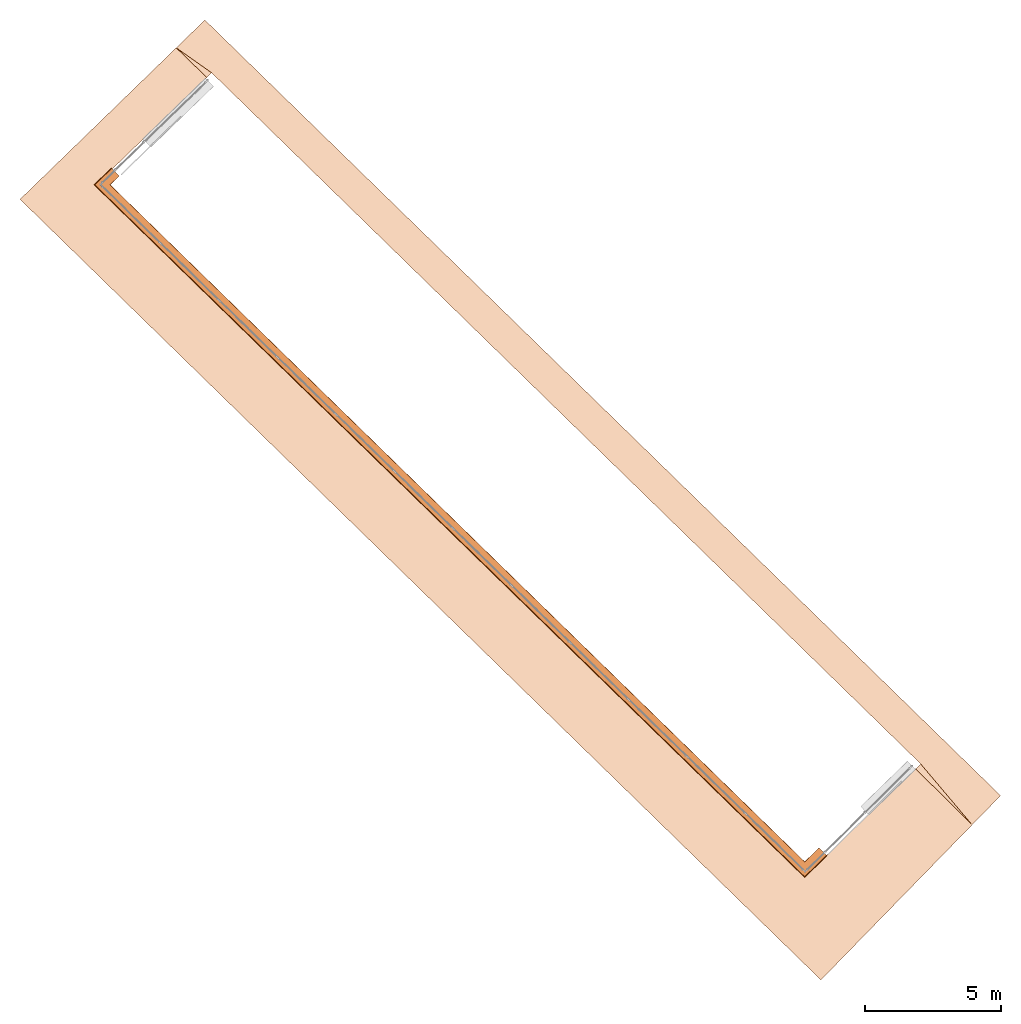
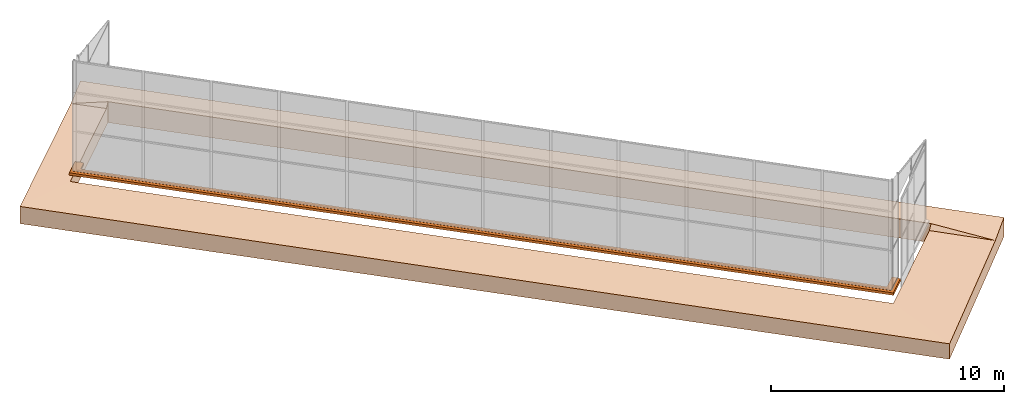
# One storey, part 13 of 13: 1 geographic element, 1 proxy.
"""IFC4 building model written with IfcOpenShell, lengths in metres."""

from ifc_helpers import new_model, entity, si_unit, converted_unit, direction, frame, origin, place, context, subcontext, project, spatial, polygons, source, transform, mapped, material, type_object, type_shapes, element, save


model = new_model("IFC4")

# Units and contexts
model_context = context("Model", 3, precision=1e-05, world=origin(), true_north=direction((6.123233995736766e-17, 1.0)))
body_context = subcontext(model_context, "Body", "Model", "MODEL_VIEW")
ifc_project = project(units=[si_unit("LENGTHUNIT", "METRE"), si_unit("AREAUNIT", "SQUARE_METRE"), si_unit("VOLUMEUNIT", "CUBIC_METRE"), converted_unit("PLANEANGLEUNIT", "DEGREE", entity("IfcPlaneAngleMeasure", 0.017453292519943278), si_unit("PLANEANGLEUNIT", "RADIAN"), dimensions=[0, 0, 0, 0, 0, 0, 0])], contexts=[model_context])

# Site, building, storey
site_placement = place(None, frame((0.0, 0.0, 0.0), z_axis=(0.0, 0.0, 1.0), x_axis=(0.7160934825303189, -0.6980043870045516, 0.0)))
site = spatial("IfcSite", under=ifc_project, at=site_placement, CompositionType="ELEMENT")
building_placement = place(site_placement, origin())
building = spatial("IfcBuilding", under=site, at=building_placement, CompositionType="ELEMENT")
storey_placement = place(building_placement, frame((0.0, 0.0, -7.0)))
storey = spatial("IfcBuildingStorey", under=building, at=storey_placement, Name="-7.00 m", CompositionType="ELEMENT", Elevation=-7.000000000000001)

# Geographic element
ifc_material_1 = material(Name="Terra", Category="Generico")
geographic_element_type = type_object("IfcGeographicElementType", Name="Solido Generico - 1000 mm", PredefinedType="TERRAIN", material=ifc_material_1)
geographic_element_placement = place(storey_placement, origin())
element("IfcGeographicElement", 1, at=geographic_element_placement, inside=storey, type_object=geographic_element_type, material=ifc_material_1, Name="Solido Generico - 1000 mm", ObjectType="Solido Generico - 1000 mm", PredefinedType="TERRAIN", context=body_context, shape_type="Tessellation", body=[
    polygons([(11.532684703476185, 0.02832929454570762, -1.3334398928547868), (11.532684703476187, -1.4706707054542927, -1.3334398928547868), (11.532684703476187, -9.430854376535772, -1.3334398928547868), (-29.559637767124112, -9.430854376535772, -1.3334398928547868), (-29.335912246860154, -1.4380963473800092, -1.3334398928547868), (-29.294865484469565, 0.02832929454570762, -1.3334398928547868), (8.610409894070742, -1.4433656579759988, -1.3334398928547868), (8.617572791938493, -1.1874658867878702, -1.3334398928547868), (-27.76667232391627, -1.1874658867878725, -1.3334398928547868), (-27.77355542108607, -1.433369573163963, -1.3334398928547868), (-27.93211017841002, -7.097854376535773, -1.3334398928547868), (8.452134937444777, -7.097854376535772, -1.3334398928547868), (11.532684703476184, 0.028329294545739528, -0.3354398928547857), (11.532684703476187, -1.4706707054542927, -0.5284398928547862), (11.532684703476187, -9.430854376535772, -0.5284398928547862), (-29.559637767124116, -9.43085437653577, -0.4324398928547861), (-29.33591224686015, -1.4380963473800092, -0.43243989285478523), (-29.294865484469558, 0.02832929454565502, -0.23943989285478473), (8.617572791938494, -1.187465886787851, -0.3354398928547857), (-27.766672323916268, -1.187465886787878, -0.23943989285478473), (-27.773555421086066, -1.433369573163964, -0.4324398928547861), (-27.932110178410024, -7.097854376535772, -0.4324398928547861), (8.452134937444779, -7.097854376535774, -0.5284398928547862), (8.610409894070742, -1.4433656579759986, -0.5284398928547862)], [[[1, 2, 3, 4, 5, 6], [7, 8, 9, 10, 11, 12]], [[2, 1, 13, 14]], [[4, 3, 15, 16]], [[5, 4, 16, 17]], [[1, 6, 18, 13]], [[9, 8, 19, 20]], [[10, 9, 20, 21]], [[12, 11, 22, 23]], [[7, 12, 23, 24]], [[3, 2, 14, 15]], [[6, 5, 17, 18]], [[8, 7, 24, 19]], [[11, 10, 21, 22]], [[16, 15, 23]], [[16, 23, 22]], [[16, 22, 21, 17]], [[20, 19, 18]], [[13, 19, 14]], [[13, 18, 19]], [[20, 18, 17]], [[20, 17, 21]], [[23, 15, 14, 24]], [[14, 19, 24]]], closed=True),
])

# Proxy
ifc_material_2 = material()
building_element_proxy_type = type_object("IfcBuildingElementProxyType", Name="Muro1:Muro", PredefinedType="NOTDEFINED", material=ifc_material_2)
shared_shape = source(origin(), body_context, "Body", "Tessellation", [
    polygons([(36.33182419133019, 1.1442330811412054, 0.13300000000005532), (36.33632242949564, 1.144107170827123, 0.12520577136594274), (36.47243725114863, 1.1402971769327928, 0.11100000000000292), (36.49487005115399, 1.139669259781557, 2.1657342585967855e-15), (36.443502514958, 1.141107089967108, 2.1657342585967855e-15), (36.443502514958, 1.141107089967108, 0.07300000000000614), (36.09363954653669, 1.1509001143956759, 0.07300000000000723), (36.09363954653669, 1.1509001143956759, 0.004000000000005588), (36.088641504130706, 1.1510400147446542, 0.004000000000005588), (36.08579560929231, 1.1511196742690655, 0.014625184089175895), (36.08579560929231, 1.1511196742690655, 0.05962518408918299), (36.078020480000816, 1.151337308137063, 0.06740335868223715), (36.08362427494708, 1.1511804521512783, 0.1130604816577353), (36.177395605690755, 1.148555696130898, 0.13300000000005532), (0.18787124100893632, 0.8823410992782678, 0.13300000000005532), (0.34229982664837544, 0.8780184842885752, 0.13300000000005532), (0.4360711573920589, 0.8753937282681948, 0.1130604816577353), (0.4416749523383237, 0.87523687228241, 0.06740335868223715), (0.4338998230468252, 0.8754545061504087, 0.05962518408918299), (0.4338998230468252, 0.8754545061504087, 0.014625184089175895), (0.43105392820842736, 0.8755341656748199, 0.004000000000005588), (0.42605588580243986, 0.8756740660237984, 0.004000000000005588), (0.42605588580243986, 0.8756740660237984, 0.07300000000004296), (0.07619291738113558, 0.885467090452365, 0.07300000000008086), (0.07619291738113125, 0.885467090452365, 2.1657342585967855e-15), (0.024825381185144182, 0.8869049206379152, 2.1657342585967855e-15), (0.04725818119050175, 0.8862770034866815, 0.11100000000000292), (0.1833730028434895, 0.88246700959235, 0.12520577136594274), (36.304361539072175, 0.16310972034517862, 0.13300000000005532), (36.3087373419672, 0.15860972034515042, 0.12520577136594166), (36.44114732310624, 0.022441586308217, 0.11100000000000292), (36.462969536069785, 1.0828671292983927e-15, 2.1657342585967855e-15), (4.331468517193571e-15, 1.0828671292983927e-15, 2.1657342585967855e-15), (0.05284617588572552, 0.05138765542899253, 2.1657342585967855e-15), (36.41300014687123, 0.051387655428993616, 2.1657342585967855e-15), (36.41300014687123, 0.051387655428993616, 0.07300000000000614), (0.05284617588572985, 0.05138765542899253, 0.07300000000008086), (0.4127801212193844, 0.40138765542902777, 0.07300000000000723), (36.07265992170444, 0.40138765542902666, 0.07300000000000723), (36.07265992170444, 0.40138765542902666, 0.004000000000005588), (0.41278012121937574, 0.40138765542902666, 0.004000000000005588), (0.41792203472411116, 0.40638765542899413, 0.004000000000005588), (36.067797918487805, 0.4063876554289952, 0.004000000000005588), (36.0650294846222, 0.40923466492512, 0.014625184089175895), (36.0650294846222, 0.40923466492512, 0.05962518408918299), (36.057465982643954, 0.4170128395181742, 0.06740335868223607), (36.062917250728724, 0.41140684972153674, 0.1130604816577353), (36.15413626702959, 0.3175987913597555, 0.13300000000005532), (0.3266131028780146, 0.31759879135975766, 0.13300000000005532), (0.1677392147603037, 0.1631097203451819, 0.1330000000000575), (0.16311149260598812, 0.15860972034515258, 0.12520577136594274), (0.023078539141327726, 0.022441586308218082, 0.11100000000000292), (0.42084985003937914, 0.4092346649251211, 0.014625184089175895), (0.42084985003937914, 0.4092346649251211, 0.05962518408918299), (0.42884879023587114, 0.41701283951817636, 0.06740335868223715), (0.4230836873072853, 0.41140684972153674, 0.1130604816577353)], [[[1, 2, 3, 4, 5, 6, 7, 8, 9, 10, 11, 12, 13, 14]], [[15, 16, 17, 18, 19, 20, 21, 22, 23, 24, 25, 26, 27, 28]], [[2, 1, 29, 30]], [[3, 2, 30, 31]], [[4, 3, 31, 32]], [[5, 4, 32, 33, 26, 25, 34, 35]], [[6, 5, 35, 36]], [[7, 6, 36, 37, 24, 23, 38, 39]], [[8, 7, 39, 40]], [[9, 8, 40, 41, 22, 21, 42, 43]], [[10, 9, 43, 44]], [[11, 10, 44, 45]], [[12, 11, 45, 46]], [[13, 12, 46, 47]], [[14, 13, 47, 48]], [[1, 14, 48, 49, 16, 15, 50, 29]], [[30, 29, 50, 51]], [[31, 30, 51, 52]], [[32, 31, 52, 33]], [[36, 35, 34, 37]], [[40, 39, 38, 41]], [[44, 43, 42, 53]], [[45, 44, 53, 54]], [[46, 45, 54, 55]], [[47, 46, 55, 56]], [[48, 47, 56, 49]], [[51, 50, 15, 28]], [[52, 51, 28, 27]], [[33, 52, 27, 26]], [[37, 34, 25, 24]], [[41, 38, 23, 22]], [[53, 42, 21, 20]], [[54, 53, 20, 19]], [[55, 54, 19, 18]], [[56, 55, 18, 17]], [[49, 56, 17, 16]]], closed=True),
])
type_shapes(building_element_proxy_type, [shared_shape])
proxy_placement = place(storey_placement, frame((-27.98542852966556, -7.149701175598145, -0.07300000000005595)))
element("IfcBuildingElementProxy", 2, at=proxy_placement, inside=storey, type_object=building_element_proxy_type, material=ifc_material_2, Name="Muro1:Muro", ObjectType="Muro1:Muro", PredefinedType="NOTDEFINED", context=body_context, shape_type="MappedRepresentation", body=[
    mapped(shared_shape, transform((0.0, 0.0, 0.0), scale=1.0)),
])

save(model, "model.ifc")
